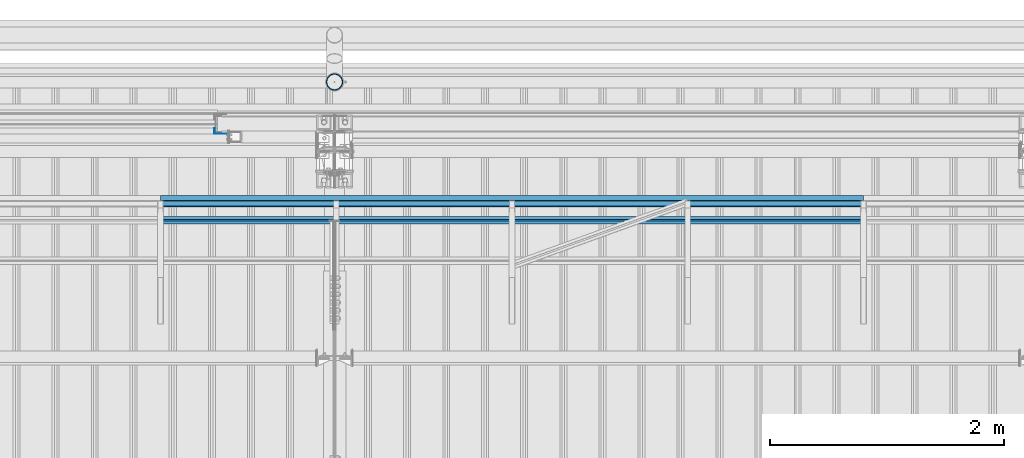
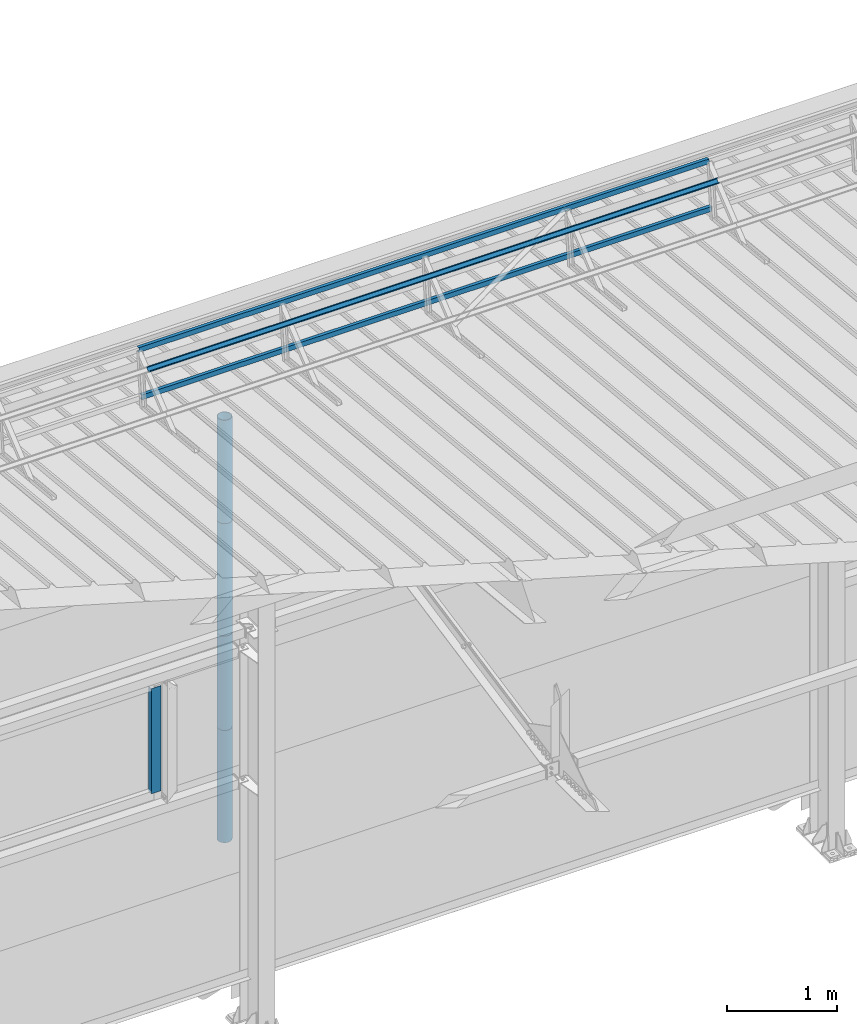
# One storey, part 75 of 709: 8 beams, 8 elements without a shape of their own.
"""IFC4 building model written with IfcOpenShell, lengths in millimetres."""

from ifc_helpers import new_model, si_unit, direction, frame, origin_with_axes, place, context, subcontext, project, spatial, line, indexed_curve, outline, extrude, material, element, aggregate, save


model = new_model("IFC4")

# Units and contexts
model_context = context("Model", 3, precision=0.2, world=origin_with_axes(), true_north=direction((0.0, 1.0)))
body_context = subcontext(model_context, "Body", "Model", "MODEL_VIEW")
ifc_project = project(units=[si_unit("LENGTHUNIT", "METRE", prefix="MILLI"), si_unit("AREAUNIT", "SQUARE_METRE"), si_unit("VOLUMEUNIT", "CUBIC_METRE"), si_unit("MASSUNIT", "GRAM", prefix="KILO"), si_unit("TIMEUNIT", "SECOND"), si_unit("PLANEANGLEUNIT", "RADIAN"), si_unit("SOLIDANGLEUNIT", "STERADIAN"), si_unit("THERMODYNAMICTEMPERATUREUNIT", "DEGREE_CELSIUS"), si_unit("LUMINOUSINTENSITYUNIT", "LUMEN")], contexts=[model_context])

# Site, building, storey
site_placement = place(None, origin_with_axes())
site = spatial("IfcSite", under=ifc_project, at=site_placement, CompositionType="ELEMENT")
building_placement = place(site_placement, origin_with_axes())
building = spatial("IfcBuilding", under=site, at=building_placement, Name="Undefined", CompositionType="ELEMENT")
storey_placement = place(building_placement, origin_with_axes())
storey = spatial("IfcBuildingStorey", under=building, at=storey_placement, Name="Undefined", CompositionType="ELEMENT", Elevation=0.0)

# Assembly, beam
assembly_1_placement = place(storey_placement, frame((38515.0, 21426.91216, 8140.47118), z_axis=(0.0, 0.9950371902, -0.099503719), x_axis=(-1.0, 0.0, 0.0)))
assembly_1 = element("IfcElementAssembly", 1, at=assembly_1_placement, inside=storey)
ifc_material = material(Name="Steel_Undefined", Category="STEEL")
beam_1_placement = place(assembly_1_placement, origin_with_axes())
beam_1 = element("IfcBeam", 2, at=beam_1_placement, material=ifc_material, ObjectType="606", context=body_context, shape_type="SolidModel", body=[
    extrude(outline(indexed_curve([(-20.0, -25.0), (20.0, -25.0), (20.0, -22.5), (-17.5, -22.5), (-17.5, 22.5), (20.0, 22.5), (20.0, 25.0), (-20.0, 25.0)], segments=[line(1, 2, 3, 4, 5, 6, 7, 8, 1)])), frame((0.0, 0.0, 0.0), z_axis=(-1.0, 0.0, 0.0), x_axis=(0.0, 0.0, 1.0)), (0.0, 0.0, -1.0), 6000.0),
])
aggregate(assembly_1, [beam_1])

assembly_2_placement = place(storey_placement, frame((38515.0, 21377.1603, 7642.95259), z_axis=(0.0, 0.9950371902, -0.099503719), x_axis=(-1.0, 0.0, 0.0)))
assembly_2 = element("IfcElementAssembly", 3, at=assembly_2_placement, inside=storey)
beam_2_placement = place(assembly_2_placement, origin_with_axes())
beam_2 = element("IfcBeam", 4, at=beam_2_placement, material=ifc_material, ObjectType="606", context=body_context, shape_type="SolidModel", body=[
    extrude(outline(indexed_curve([(-20.0, -25.0), (20.0, -25.0), (20.0, -22.5), (-17.5, -22.5), (-17.5, 22.5), (20.0, 22.5), (20.0, 25.0), (-20.0, 25.0)], segments=[line(1, 2, 3, 4, 5, 6, 7, 8, 1)])), frame((0.0, 0.0, 0.0), z_axis=(-1.0, 0.0, 0.0), x_axis=(0.0, 0.0, 1.0)), (0.0, 0.0, -1.0), 6000.0),
])
aggregate(assembly_2, [beam_2])

assembly_3_placement = place(storey_placement, frame((38515.0, 21239.5552, 8031.29285), z_axis=(0.0, -0.6332377902, 0.7739572992), x_axis=(-1.0, 0.0, 0.0)))
assembly_3 = element("IfcElementAssembly", 5, at=assembly_3_placement, inside=storey)
beam_3_placement = place(assembly_3_placement, origin_with_axes())
beam_3 = element("IfcBeam", 6, at=beam_3_placement, material=ifc_material, ObjectType="606", context=body_context, shape_type="SolidModel", body=[
    extrude(outline(indexed_curve([(-20.0, -25.0), (20.0, -25.0), (20.0, -22.5), (-17.5, -22.5), (-17.5, 22.5), (20.0, 22.5), (20.0, 25.0), (-20.0, 25.0)], segments=[line(1, 2, 3, 4, 5, 6, 7, 8, 1)])), frame((0.0, 0.0, 0.0), z_axis=(-1.0, 0.0, 0.0), x_axis=(0.0, 0.0, 1.0)), (0.0, 0.0, -1.0), 6000.0),
])
aggregate(assembly_3, [beam_3])

assembly_4_placement = place(storey_placement, frame((32975.0, 22001.0, 3870.0), z_axis=(0.0, -1.0, 0.0), x_axis=(0.0, 0.0, -1.0)))
assembly_4 = element("IfcElementAssembly", 7, at=assembly_4_placement, inside=storey)
beam_4_placement = place(assembly_4_placement, origin_with_axes())
beam_4 = element("IfcBeam", 8, at=beam_4_placement, material=ifc_material, context=body_context, shape_type="SolidModel", body=[
    extrude(outline(indexed_curve([(-25.0, -1.0), (25.0, -1.0), (25.0, 99.0), (23.0, 99.0), (23.0, 1.0), (-25.0, 1.0)], segments=[line(1, 2, 3, 4, 5, 6, 1)])), frame((0.0, 0.0, 0.0), z_axis=(-1.0, 0.0, 0.0), x_axis=(0.0, 0.0, 1.0)), (0.0, 0.0, -1.0), 1170.0),
])
aggregate(assembly_4, [beam_4])

assembly_5_placement = place(storey_placement, frame((34000.0, 22420.0, 6276.92297), z_axis=(0.0, -1.0, 0.0), x_axis=(0.0, 0.0, -1.0)))
assembly_5 = element("IfcElementAssembly", 9, at=assembly_5_placement, inside=storey)
beam_5_placement = place(assembly_5_placement, origin_with_axes())
beam_5 = element("IfcBeam", 10, at=beam_5_placement, material=ifc_material, ObjectType="614", context=body_context, shape_type="SolidModel", body=[
    extrude(outline(indexed_curve([(70.0, 0.0), (69.61653, 7.31699), (68.47033, 14.55382), (66.57396, 21.63119), (63.94818, 28.47157), (60.62178, 35.0), (56.63119, 41.14497), (52.02014, 46.83914), (46.83914, 52.02014), (41.14497, 56.63119), (35.0, 60.62178), (28.47157, 63.94818), (21.63119, 66.57396), (14.55382, 68.47033), (7.31699, 69.61653), (0.0, 70.0), (-7.31699, 69.61653), (-14.55382, 68.47033), (-21.63119, 66.57396), (-28.47157, 63.94818), (-35.0, 60.62178), (-41.14497, 56.63119), (-46.83914, 52.02014), (-52.02014, 46.83914), (-56.63119, 41.14497), (-60.62178, 35.0), (-63.94818, 28.47157), (-66.57396, 21.63119), (-68.47033, 14.55382), (-69.61653, 7.31699), (-70.0, 0.0), (-69.61653, -7.31699), (-68.47033, -14.55382), (-66.57396, -21.63119), (-63.94818, -28.47157), (-60.62178, -35.0), (-56.63119, -41.14497), (-52.02014, -46.83914), (-46.83914, -52.02014), (-41.14497, -56.63119), (-35.0, -60.62178), (-28.47157, -63.94818), (-21.63119, -66.57396), (-14.55382, -68.47033), (-7.31699, -69.61653), (0.0, -70.0), (7.31699, -69.61653), (14.55382, -68.47033), (21.63119, -66.57396), (28.47157, -63.94818), (35.0, -60.62178), (41.14497, -56.63119), (46.83914, -52.02014), (52.02014, -46.83914), (56.63119, -41.14497), (60.62178, -35.0), (63.94818, -28.47157), (66.57396, -21.63119), (68.47033, -14.55382), (69.61653, -7.31699)], segments=[line(1, 2, 3, 4, 5, 6, 7, 8, 9, 10, 11, 12, 13, 14, 15, 16, 17, 18, 19, 20, 21, 22, 23, 24, 25, 26, 27, 28, 29, 30, 31, 32, 33, 34, 35, 36, 37, 38, 39, 40, 41, 42, 43, 44, 45, 46, 47, 48, 49, 50, 51, 52, 53, 54, 55, 56, 57, 58, 59, 60, 1)]), holes=[indexed_curve([(65.0, 0.0), (64.64392, -6.79435), (63.57959, -13.51426), (61.81867, -20.0861), (59.38045, -26.43788), (56.29165, -32.5), (52.5861, -38.20604), (48.30441, -43.49349), (43.49349, -48.30441), (38.20604, -52.5861), (32.5, -56.29165), (26.43788, -59.38045), (20.0861, -61.81867), (13.51426, -63.57959), (6.79435, -64.64392), (0.0, -65.0), (-6.79435, -64.64392), (-13.51426, -63.57959), (-20.0861, -61.81867), (-26.43788, -59.38045), (-32.5, -56.29165), (-38.20604, -52.5861), (-43.49349, -48.30441), (-48.30441, -43.49349), (-52.5861, -38.20604), (-56.29165, -32.5), (-59.38045, -26.43788), (-61.81867, -20.0861), (-63.57959, -13.51426), (-64.64392, -6.79435), (-65.0, 0.0), (-64.64392, 6.79435), (-63.57959, 13.51426), (-61.81867, 20.0861), (-59.38045, 26.43788), (-56.29165, 32.5), (-52.5861, 38.20604), (-48.30441, 43.49349), (-43.49349, 48.30441), (-38.20604, 52.5861), (-32.5, 56.29165), (-26.43788, 59.38045), (-20.0861, 61.81867), (-13.51426, 63.57959), (-6.79435, 64.64392), (0.0, 65.0), (6.79435, 64.64392), (13.51426, 63.57959), (20.0861, 61.81867), (26.43788, 59.38045), (32.5, 56.29165), (38.20604, 52.5861), (43.49349, 48.30441), (48.30441, 43.49349), (52.5861, 38.20604), (56.29165, 32.5), (59.38045, 26.43788), (61.81867, 20.0861), (63.57959, 13.51426), (64.64392, 6.79435)], segments=[line(1, 2, 3, 4, 5, 6, 7, 8, 9, 10, 11, 12, 13, 14, 15, 16, 17, 18, 19, 20, 21, 22, 23, 24, 25, 26, 27, 28, 29, 30, 31, 32, 33, 34, 35, 36, 37, 38, 39, 40, 41, 42, 43, 44, 45, 46, 47, 48, 49, 50, 51, 52, 53, 54, 55, 56, 57, 58, 59, 60, 1)])]), frame((0.0, 0.0, 0.0), z_axis=(-1.0, 0.0, 0.0), x_axis=(0.0, 0.0, 1.0)), (0.0, 0.0, -1.0), 1250.0),
])
aggregate(assembly_5, [beam_5])

assembly_6_placement = place(storey_placement, frame((34000.0, 22420.0, 5126.92297), z_axis=(0.0, -1.0, 0.0), x_axis=(0.0, 0.0, -1.0)))
assembly_6 = element("IfcElementAssembly", 11, at=assembly_6_placement, inside=storey)
beam_6_placement = place(assembly_6_placement, origin_with_axes())
beam_6 = element("IfcBeam", 12, at=beam_6_placement, material=ifc_material, ObjectType="614", context=body_context, shape_type="SolidModel", body=[
    extrude(outline(indexed_curve([(70.0, 0.0), (69.61653, 7.31699), (68.47033, 14.55382), (66.57396, 21.63119), (63.94818, 28.47157), (60.62178, 35.0), (56.63119, 41.14497), (52.02014, 46.83914), (46.83914, 52.02014), (41.14497, 56.63119), (35.0, 60.62178), (28.47157, 63.94818), (21.63119, 66.57396), (14.55382, 68.47033), (7.31699, 69.61653), (0.0, 70.0), (-7.31699, 69.61653), (-14.55382, 68.47033), (-21.63119, 66.57396), (-28.47157, 63.94818), (-35.0, 60.62178), (-41.14497, 56.63119), (-46.83914, 52.02014), (-52.02014, 46.83914), (-56.63119, 41.14497), (-60.62178, 35.0), (-63.94818, 28.47157), (-66.57396, 21.63119), (-68.47033, 14.55382), (-69.61653, 7.31699), (-70.0, 0.0), (-69.61653, -7.31699), (-68.47033, -14.55382), (-66.57396, -21.63119), (-63.94818, -28.47157), (-60.62178, -35.0), (-56.63119, -41.14497), (-52.02014, -46.83914), (-46.83914, -52.02014), (-41.14497, -56.63119), (-35.0, -60.62178), (-28.47157, -63.94818), (-21.63119, -66.57396), (-14.55382, -68.47033), (-7.31699, -69.61653), (0.0, -70.0), (7.31699, -69.61653), (14.55382, -68.47033), (21.63119, -66.57396), (28.47157, -63.94818), (35.0, -60.62178), (41.14497, -56.63119), (46.83914, -52.02014), (52.02014, -46.83914), (56.63119, -41.14497), (60.62178, -35.0), (63.94818, -28.47157), (66.57396, -21.63119), (68.47033, -14.55382), (69.61653, -7.31699)], segments=[line(1, 2, 3, 4, 5, 6, 7, 8, 9, 10, 11, 12, 13, 14, 15, 16, 17, 18, 19, 20, 21, 22, 23, 24, 25, 26, 27, 28, 29, 30, 31, 32, 33, 34, 35, 36, 37, 38, 39, 40, 41, 42, 43, 44, 45, 46, 47, 48, 49, 50, 51, 52, 53, 54, 55, 56, 57, 58, 59, 60, 1)]), holes=[indexed_curve([(65.0, 0.0), (64.64392, -6.79435), (63.57959, -13.51426), (61.81867, -20.0861), (59.38045, -26.43788), (56.29165, -32.5), (52.5861, -38.20604), (48.30441, -43.49349), (43.49349, -48.30441), (38.20604, -52.5861), (32.5, -56.29165), (26.43788, -59.38045), (20.0861, -61.81867), (13.51426, -63.57959), (6.79435, -64.64392), (0.0, -65.0), (-6.79435, -64.64392), (-13.51426, -63.57959), (-20.0861, -61.81867), (-26.43788, -59.38045), (-32.5, -56.29165), (-38.20604, -52.5861), (-43.49349, -48.30441), (-48.30441, -43.49349), (-52.5861, -38.20604), (-56.29165, -32.5), (-59.38045, -26.43788), (-61.81867, -20.0861), (-63.57959, -13.51426), (-64.64392, -6.79435), (-65.0, 0.0), (-64.64392, 6.79435), (-63.57959, 13.51426), (-61.81867, 20.0861), (-59.38045, 26.43788), (-56.29165, 32.5), (-52.5861, 38.20604), (-48.30441, 43.49349), (-43.49349, 48.30441), (-38.20604, 52.5861), (-32.5, 56.29165), (-26.43788, 59.38045), (-20.0861, 61.81867), (-13.51426, 63.57959), (-6.79435, 64.64392), (0.0, 65.0), (6.79435, 64.64392), (13.51426, 63.57959), (20.0861, 61.81867), (26.43788, 59.38045), (32.5, 56.29165), (38.20604, 52.5861), (43.49349, 48.30441), (48.30441, 43.49349), (52.5861, 38.20604), (56.29165, 32.5), (59.38045, 26.43788), (61.81867, 20.0861), (63.57959, 13.51426), (64.64392, 6.79435)], segments=[line(1, 2, 3, 4, 5, 6, 7, 8, 9, 10, 11, 12, 13, 14, 15, 16, 17, 18, 19, 20, 21, 22, 23, 24, 25, 26, 27, 28, 29, 30, 31, 32, 33, 34, 35, 36, 37, 38, 39, 40, 41, 42, 43, 44, 45, 46, 47, 48, 49, 50, 51, 52, 53, 54, 55, 56, 57, 58, 59, 60, 1)])]), frame((0.0, 0.0, 0.0), z_axis=(-1.0, 0.0, 0.0), x_axis=(0.0, 0.0, 1.0)), (0.0, 0.0, -1.0), 1250.0),
])
aggregate(assembly_6, [beam_6])

assembly_7_placement = place(storey_placement, frame((34000.0, 22420.0, 3976.92297), z_axis=(0.0, -1.0, 0.0), x_axis=(0.0, 0.0, -1.0)))
assembly_7 = element("IfcElementAssembly", 13, at=assembly_7_placement, inside=storey)
beam_7_placement = place(assembly_7_placement, origin_with_axes())
beam_7 = element("IfcBeam", 14, at=beam_7_placement, material=ifc_material, ObjectType="614", context=body_context, shape_type="SolidModel", body=[
    extrude(outline(indexed_curve([(70.0, 0.0), (69.61653, 7.31699), (68.47033, 14.55382), (66.57396, 21.63119), (63.94818, 28.47157), (60.62178, 35.0), (56.63119, 41.14497), (52.02014, 46.83914), (46.83914, 52.02014), (41.14497, 56.63119), (35.0, 60.62178), (28.47157, 63.94818), (21.63119, 66.57396), (14.55382, 68.47033), (7.31699, 69.61653), (0.0, 70.0), (-7.31699, 69.61653), (-14.55382, 68.47033), (-21.63119, 66.57396), (-28.47157, 63.94818), (-35.0, 60.62178), (-41.14497, 56.63119), (-46.83914, 52.02014), (-52.02014, 46.83914), (-56.63119, 41.14497), (-60.62178, 35.0), (-63.94818, 28.47157), (-66.57396, 21.63119), (-68.47033, 14.55382), (-69.61653, 7.31699), (-70.0, 0.0), (-69.61653, -7.31699), (-68.47033, -14.55382), (-66.57396, -21.63119), (-63.94818, -28.47157), (-60.62178, -35.0), (-56.63119, -41.14497), (-52.02014, -46.83914), (-46.83914, -52.02014), (-41.14497, -56.63119), (-35.0, -60.62178), (-28.47157, -63.94818), (-21.63119, -66.57396), (-14.55382, -68.47033), (-7.31699, -69.61653), (0.0, -70.0), (7.31699, -69.61653), (14.55382, -68.47033), (21.63119, -66.57396), (28.47157, -63.94818), (35.0, -60.62178), (41.14497, -56.63119), (46.83914, -52.02014), (52.02014, -46.83914), (56.63119, -41.14497), (60.62178, -35.0), (63.94818, -28.47157), (66.57396, -21.63119), (68.47033, -14.55382), (69.61653, -7.31699)], segments=[line(1, 2, 3, 4, 5, 6, 7, 8, 9, 10, 11, 12, 13, 14, 15, 16, 17, 18, 19, 20, 21, 22, 23, 24, 25, 26, 27, 28, 29, 30, 31, 32, 33, 34, 35, 36, 37, 38, 39, 40, 41, 42, 43, 44, 45, 46, 47, 48, 49, 50, 51, 52, 53, 54, 55, 56, 57, 58, 59, 60, 1)]), holes=[indexed_curve([(65.0, 0.0), (64.64392, -6.79435), (63.57959, -13.51426), (61.81867, -20.0861), (59.38045, -26.43788), (56.29165, -32.5), (52.5861, -38.20604), (48.30441, -43.49349), (43.49349, -48.30441), (38.20604, -52.5861), (32.5, -56.29165), (26.43788, -59.38045), (20.0861, -61.81867), (13.51426, -63.57959), (6.79435, -64.64392), (0.0, -65.0), (-6.79435, -64.64392), (-13.51426, -63.57959), (-20.0861, -61.81867), (-26.43788, -59.38045), (-32.5, -56.29165), (-38.20604, -52.5861), (-43.49349, -48.30441), (-48.30441, -43.49349), (-52.5861, -38.20604), (-56.29165, -32.5), (-59.38045, -26.43788), (-61.81867, -20.0861), (-63.57959, -13.51426), (-64.64392, -6.79435), (-65.0, 0.0), (-64.64392, 6.79435), (-63.57959, 13.51426), (-61.81867, 20.0861), (-59.38045, 26.43788), (-56.29165, 32.5), (-52.5861, 38.20604), (-48.30441, 43.49349), (-43.49349, 48.30441), (-38.20604, 52.5861), (-32.5, 56.29165), (-26.43788, 59.38045), (-20.0861, 61.81867), (-13.51426, 63.57959), (-6.79435, 64.64392), (0.0, 65.0), (6.79435, 64.64392), (13.51426, 63.57959), (20.0861, 61.81867), (26.43788, 59.38045), (32.5, 56.29165), (38.20604, 52.5861), (43.49349, 48.30441), (48.30441, 43.49349), (52.5861, 38.20604), (56.29165, 32.5), (59.38045, 26.43788), (61.81867, 20.0861), (63.57959, 13.51426), (64.64392, 6.79435)], segments=[line(1, 2, 3, 4, 5, 6, 7, 8, 9, 10, 11, 12, 13, 14, 15, 16, 17, 18, 19, 20, 21, 22, 23, 24, 25, 26, 27, 28, 29, 30, 31, 32, 33, 34, 35, 36, 37, 38, 39, 40, 41, 42, 43, 44, 45, 46, 47, 48, 49, 50, 51, 52, 53, 54, 55, 56, 57, 58, 59, 60, 1)])]), frame((0.0, 0.0, 0.0), z_axis=(-1.0, 0.0, 0.0), x_axis=(0.0, 0.0, 1.0)), (0.0, 0.0, -1.0), 1250.0),
])
aggregate(assembly_7, [beam_7])

assembly_8_placement = place(storey_placement, frame((34000.0, 22420.0, 2826.92297), z_axis=(0.0, -1.0, 0.0), x_axis=(0.0, 0.0, -1.0)))
assembly_8 = element("IfcElementAssembly", 15, at=assembly_8_placement, inside=storey)
beam_8_placement = place(assembly_8_placement, origin_with_axes())
beam_8 = element("IfcBeam", 16, at=beam_8_placement, material=ifc_material, ObjectType="614", context=body_context, shape_type="SolidModel", body=[
    extrude(outline(indexed_curve([(70.0, 0.0), (69.61653, 7.31699), (68.47033, 14.55382), (66.57396, 21.63119), (63.94818, 28.47157), (60.62178, 35.0), (56.63119, 41.14497), (52.02014, 46.83914), (46.83914, 52.02014), (41.14497, 56.63119), (35.0, 60.62178), (28.47157, 63.94818), (21.63119, 66.57396), (14.55382, 68.47033), (7.31699, 69.61653), (0.0, 70.0), (-7.31699, 69.61653), (-14.55382, 68.47033), (-21.63119, 66.57396), (-28.47157, 63.94818), (-35.0, 60.62178), (-41.14497, 56.63119), (-46.83914, 52.02014), (-52.02014, 46.83914), (-56.63119, 41.14497), (-60.62178, 35.0), (-63.94818, 28.47157), (-66.57396, 21.63119), (-68.47033, 14.55382), (-69.61653, 7.31699), (-70.0, 0.0), (-69.61653, -7.31699), (-68.47033, -14.55382), (-66.57396, -21.63119), (-63.94818, -28.47157), (-60.62178, -35.0), (-56.63119, -41.14497), (-52.02014, -46.83914), (-46.83914, -52.02014), (-41.14497, -56.63119), (-35.0, -60.62178), (-28.47157, -63.94818), (-21.63119, -66.57396), (-14.55382, -68.47033), (-7.31699, -69.61653), (0.0, -70.0), (7.31699, -69.61653), (14.55382, -68.47033), (21.63119, -66.57396), (28.47157, -63.94818), (35.0, -60.62178), (41.14497, -56.63119), (46.83914, -52.02014), (52.02014, -46.83914), (56.63119, -41.14497), (60.62178, -35.0), (63.94818, -28.47157), (66.57396, -21.63119), (68.47033, -14.55382), (69.61653, -7.31699)], segments=[line(1, 2, 3, 4, 5, 6, 7, 8, 9, 10, 11, 12, 13, 14, 15, 16, 17, 18, 19, 20, 21, 22, 23, 24, 25, 26, 27, 28, 29, 30, 31, 32, 33, 34, 35, 36, 37, 38, 39, 40, 41, 42, 43, 44, 45, 46, 47, 48, 49, 50, 51, 52, 53, 54, 55, 56, 57, 58, 59, 60, 1)]), holes=[indexed_curve([(65.0, 0.0), (64.64392, -6.79435), (63.57959, -13.51426), (61.81867, -20.0861), (59.38045, -26.43788), (56.29165, -32.5), (52.5861, -38.20604), (48.30441, -43.49349), (43.49349, -48.30441), (38.20604, -52.5861), (32.5, -56.29165), (26.43788, -59.38045), (20.0861, -61.81867), (13.51426, -63.57959), (6.79435, -64.64392), (0.0, -65.0), (-6.79435, -64.64392), (-13.51426, -63.57959), (-20.0861, -61.81867), (-26.43788, -59.38045), (-32.5, -56.29165), (-38.20604, -52.5861), (-43.49349, -48.30441), (-48.30441, -43.49349), (-52.5861, -38.20604), (-56.29165, -32.5), (-59.38045, -26.43788), (-61.81867, -20.0861), (-63.57959, -13.51426), (-64.64392, -6.79435), (-65.0, 0.0), (-64.64392, 6.79435), (-63.57959, 13.51426), (-61.81867, 20.0861), (-59.38045, 26.43788), (-56.29165, 32.5), (-52.5861, 38.20604), (-48.30441, 43.49349), (-43.49349, 48.30441), (-38.20604, 52.5861), (-32.5, 56.29165), (-26.43788, 59.38045), (-20.0861, 61.81867), (-13.51426, 63.57959), (-6.79435, 64.64392), (0.0, 65.0), (6.79435, 64.64392), (13.51426, 63.57959), (20.0861, 61.81867), (26.43788, 59.38045), (32.5, 56.29165), (38.20604, 52.5861), (43.49349, 48.30441), (48.30441, 43.49349), (52.5861, 38.20604), (56.29165, 32.5), (59.38045, 26.43788), (61.81867, 20.0861), (63.57959, 13.51426), (64.64392, 6.79435)], segments=[line(1, 2, 3, 4, 5, 6, 7, 8, 9, 10, 11, 12, 13, 14, 15, 16, 17, 18, 19, 20, 21, 22, 23, 24, 25, 26, 27, 28, 29, 30, 31, 32, 33, 34, 35, 36, 37, 38, 39, 40, 41, 42, 43, 44, 45, 46, 47, 48, 49, 50, 51, 52, 53, 54, 55, 56, 57, 58, 59, 60, 1)])]), frame((0.0, 0.0, 0.0), z_axis=(-1.0, 0.0, 0.0), x_axis=(0.0, 0.0, 1.0)), (0.0, 0.0, -1.0), 1250.0),
])
aggregate(assembly_8, [beam_8])

save(model, "model.ifc")
